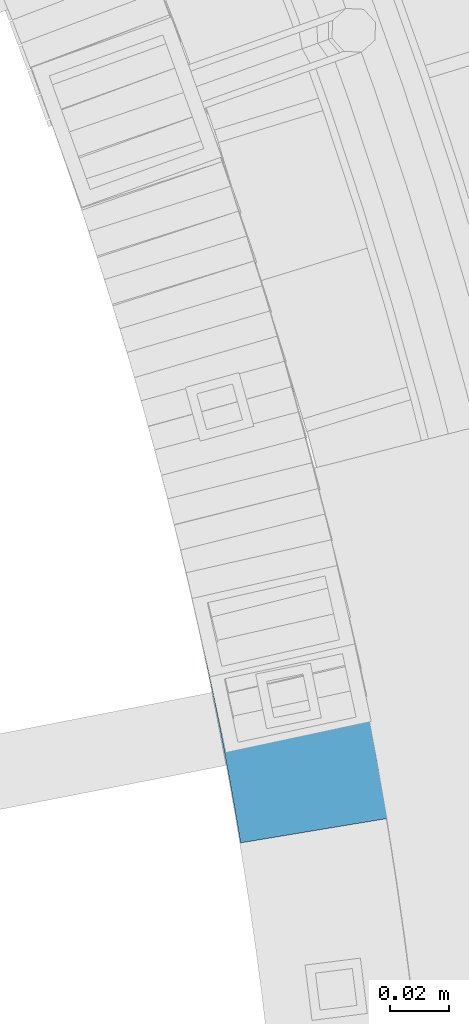
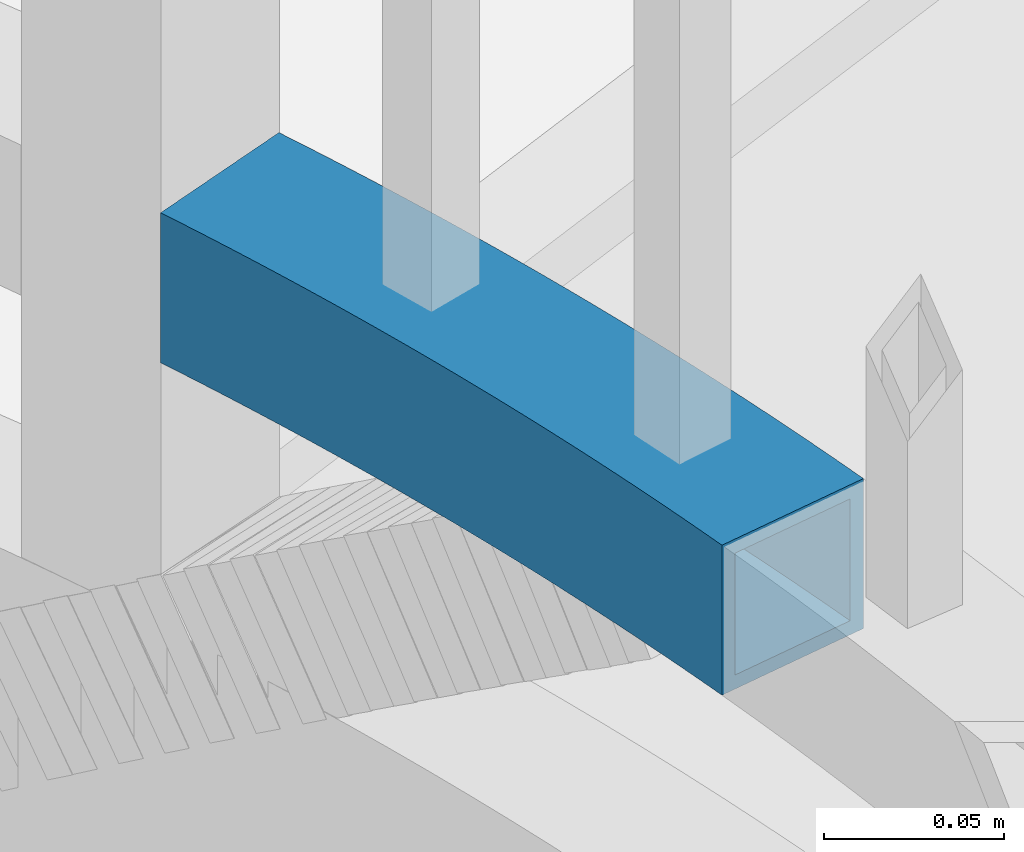
# One storey, part 501 of 975: 1 beam.
"""IFC2X3 building model written with IfcOpenShell, lengths in millimetres."""

from ifc_helpers import new_model, si_unit, frame, origin_with_axes, place, context, subcontext, project, spatial, faceted_brep, material, type_object, element, save


model = new_model("IFC2X3")

# Units and contexts
model_context = context("Model", 3, precision=1e-05, world=origin_with_axes())
body_context = subcontext(model_context, "Body", "Model", "MODEL_VIEW")
ifc_project = project(units=[si_unit("LENGTHUNIT", "METRE", prefix="MILLI"), si_unit("AREAUNIT", "SQUARE_METRE"), si_unit("VOLUMEUNIT", "CUBIC_METRE"), si_unit("MASSUNIT", "GRAM", prefix="KILO"), si_unit("TIMEUNIT", "SECOND"), si_unit("PLANEANGLEUNIT", "RADIAN"), si_unit("SOLIDANGLEUNIT", "STERADIAN"), si_unit("THERMODYNAMICTEMPERATUREUNIT", "DEGREE_CELSIUS"), si_unit("LUMINOUSINTENSITYUNIT", "LUMEN")], contexts=[model_context])

# Site, building, storey
site_placement = place(None, origin_with_axes())
site = spatial("IfcSite", under=ifc_project, at=site_placement, CompositionType="ELEMENT")
building_placement = place(site_placement, origin_with_axes())
building = spatial("IfcBuilding", under=site, at=building_placement, Name="Undefined", CompositionType="ELEMENT")
storey_placement = place(building_placement, origin_with_axes())
storey = spatial("IfcBuildingStorey", under=building, at=storey_placement, Name="Undefined", CompositionType="ELEMENT", Elevation=0.0)

# Beam
ifc_material = material()
beam_type = type_object("IfcBeamType", Name="HSS2X2X.188_TUBES", PredefinedType="NOTDEFINED")
beam_placement = place(storey_placement, frame((36048.7809654732, 3877.2993769869, 2298.70000076294), z_axis=(0.0, 0.0, 1.0), x_axis=(0.252202304925183, -0.967674530712897, 0.0)))
element("IfcBeam", 1, at=beam_placement, inside=storey, type_object=beam_type, material=ifc_material, Name="HANDRAIL", ObjectType="HSS2X2X.188_TUBES", context=body_context, shape_type="Brep", body=[
    faceted_brep([(23.9244235525521, 27.4337792830265, -25.4000000000001), (23.9244235525521, 27.4337792830265, 25.4000000000001), (28.2983125438623, 27.7431184082016, 25.4000000000001), (28.2983125438623, 27.7431184082016, -25.4000000000001), (32.673130547797, 28.0390289269781, 25.4000000000001), (32.673130547797, 28.0390289269781, -25.4000000000001), (37.0488363362747, 28.3215080507071, 25.4000000000001), (37.0488363362747, 28.3215080507071, -25.4000000000001), (41.4253886728502, 28.5905531173339, 25.4000000000001), (41.4253886728502, 28.5905531173339, -25.4000000000001), (45.8027463131011, 28.846161591362, 25.4000000000001), (45.8027463131011, 28.846161591362, -25.4000000000001), (50.1808680050126, 29.0883310639838, 25.4000000000001), (50.1808680050126, 29.0883310639838, -25.4000000000001), (54.5597124893729, 29.3170592529859, 25.4000000000001), (54.5597124893729, 29.3170592529859, -25.4000000000001), (58.9392385001574, 29.5323440028515, 25.4000000000001), (58.9392385001574, 29.5323440028515, -25.4000000000001), (63.3194047649195, 29.7341832847378, 25.4000000000001), (63.3194047649195, 29.7341832847378, -25.4000000000001), (67.7001700051733, 29.9225751965278, 25.4000000000001), (67.7001700051733, 29.9225751965278, -25.4000000000001), (72.0814929367998, 30.0975179628367, 25.4000000000001), (72.0814929367998, 30.0975179628367, -25.4000000000001), (76.4633322704121, 30.2590099349909, 25.4000000000001), (76.4633322704121, 30.2590099349909, -25.4000000000001), (80.845646711763, 30.4070495911074, 25.4000000000001), (80.845646711763, 30.4070495911074, -25.4000000000001), (85.2283949621278, 30.5416355360649, 25.4000000000001), (85.2283949621278, 30.5416355360649, -25.4000000000001), (89.6115357186954, 30.662766501533, 25.4000000000001), (89.6115357186954, 30.662766501533, -25.4000000000001), (93.995027674945, 30.7704413459796, 25.4000000000001), (93.995027674945, 30.7704413459796, -25.4000000000001), (98.3788295210634, 30.864659054685, 25.4000000000001), (98.3788295210634, 30.864659054685, -25.4000000000001), (102.762899944306, 30.9454187397423, 25.4000000000001), (102.762899944306, 30.9454187397423, -25.4000000000001), (107.147197629394, 31.012719640079, 25.4000000000001), (107.147197629394, 31.012719640079, -25.4000000000001), (111.531681258915, 31.0665611214499, 25.4000000000001), (111.531681258915, 31.0665611214499, -25.4000000000001), (115.916309513703, 31.1069426764516, 25.4000000000001), (115.916309513703, 31.1069426764516, -25.4000000000001), (120.301041073226, 31.1338639245441, 25.4000000000001), (120.301041073226, 31.1338639245441, -25.4000000000001), (124.685834615975, 31.1473246120149, 25.4000000000001), (124.685834615975, 31.1473246120149, -25.4000000000001), (129.070648819868, 31.1473246120077, 25.4000000000001), (129.070648819868, 31.1473246120077, -25.4000000000001), (133.45544236262, 31.1338639245296, 25.4000000000001), (133.45544236262, 31.1338639245296, -25.4000000000001), (137.840173922141, 31.106942676437, 25.4000000000001), (137.840173922141, 31.106942676437, -25.4000000000001), (142.224802176928, 31.0665611214208, 25.4000000000001), (142.224802176928, 31.0665611214208, -25.4000000000001), (146.609285806451, 31.0127196400354, 25.4000000000001), (146.609285806451, 31.0127196400354, -25.4000000000001), (150.99358349154, 30.9454187396914, 25.4000000000001), (150.99358349154, 30.9454187396914, -25.4000000000001), (155.377653914779, 30.8646590546268, 25.4000000000001), (155.377653914779, 30.8646590546268, -25.4000000000001), (159.761455760896, 30.7704413459142, 25.4000000000001), (159.761455760896, 30.7704413459142, -25.4000000000001), (164.14494771715, 30.662766501453, 25.4000000000001), (164.14494771715, 30.662766501453, -25.4000000000001), (168.528088473715, 30.5416355359775, 25.4000000000001), (168.528088473715, 30.5416355359775, -25.4000000000001), (172.910836724081, 30.4070495910128, 25.4000000000001), (172.910836724081, 30.4070495910128, -25.4000000000001), (177.293151165432, 30.259009934889, 25.4000000000001), (177.293151165432, 30.259009934889, -25.4000000000001), (181.674990499043, 30.0975179627276, 25.4000000000001), (181.674990499043, 30.0975179627276, -25.4000000000001), (186.056313430669, 29.9225751964186, 25.4000000000001), (186.056313430669, 29.9225751964186, -25.4000000000001), (190.437078670922, 29.7341832846068, 25.4000000000001), (190.437078670922, 29.7341832846068, -25.4000000000001), (194.817244935684, 29.5323440027132, 25.4000000000001), (194.817244935684, 29.5323440027132, -25.4000000000001), (199.19677094647, 29.3170592528477, 25.4000000000001), (199.19677094647, 29.3170592528477, -25.4000000000001), (203.575615430829, 29.088331063831, 25.4000000000001), (203.575615430829, 29.088331063831, -25.4000000000001), (207.953737122741, 28.846161591202, 25.4000000000001), (207.953737122741, 28.846161591202, -25.4000000000001), (212.33109476299, 28.590553117152, 25.4000000000001), (212.33109476299, 28.590553117152, -25.4000000000001), (216.707647099567, 28.3215080505252, 25.4000000000001), (216.707647099567, 28.3215080505252, -25.4000000000001), (221.083352888043, 28.0390289267889, 25.4000000000001), (221.083352888043, 28.0390289267889, -25.4000000000001), (225.458170891976, 27.7431184080051, 25.4000000000001), (225.458170891976, 27.7431184080051, -25.4000000000001), (229.832059883287, 27.4337792828301, 25.4000000000001), (229.832059883287, 27.4337792828301, -25.4000000000001), (234.204978642647, 27.111014466449, 25.4000000000001), (234.204978642647, 27.111014466449, -25.4000000000001), (238.576885959879, 26.774827000605, 25.4000000000001), (238.576885959879, 26.774827000605, -25.4000000000001), (242.947740634334, 26.4252200534829, 25.4000000000001), (242.947740634334, 26.4252200534829, -25.4000000000001), (247.317501475278, 26.0621969197819, 25.4000000000001), (247.317501475278, 26.0621969197819, -25.4000000000001), (251.686127302295, 25.6857610206207, 25.4000000000001), (251.686127302295, 25.6857610206207, -25.4000000000001), (247.247270868133, -24.9199358283295, 25.4000000000001), (247.247270868133, -24.9199358283295, -25.4000000000001), (251.45938992594, -25.2959159039965, -25.4000000000001), (251.45938992594, -25.2959159039965, 25.4000000000001), (243.034017458249, -24.5568880649007, 25.4000000000001), (243.034017458249, -24.5568880649007, -25.4000000000001), (238.819669401789, -24.2067760350546, 25.4000000000001), (238.819669401789, -24.2067760350546, -25.4000000000001), (234.604266414571, -23.8696030382416, 25.4000000000001), (234.604266414571, -23.8696030382416, -25.4000000000001), (230.387848222354, -23.5453722519596, 25.4000000000001), (230.387848222354, -23.5453722519596, -25.4000000000001), (226.170454560464, -23.2340867317544, 25.4000000000001), (226.170454560464, -23.2340867317544, -25.4000000000001), (221.952125173425, -22.9357494111391, 25.4000000000001), (221.952125173425, -22.9357494111391, -25.4000000000001), (217.732899814573, -22.6503631016603, 25.4000000000001), (217.732899814573, -22.6503631016603, -25.4000000000001), (213.512818245687, -22.3779304927666, 25.4000000000001), (213.512818245687, -22.3779304927666, -25.4000000000001), (209.291920236621, -22.1184541518596, 25.4000000000001), (209.291920236621, -22.1184541518596, -25.4000000000001), (205.070245564919, -21.8719365242287, 25.4000000000001), (205.070245564919, -21.8719365242287, -25.4000000000001), (200.847834015442, -21.6383799330506, 25.4000000000001), (200.847834015442, -21.6383799330506, -25.4000000000001), (196.624725380004, -21.417786579339, 25.4000000000001), (196.624725380004, -21.417786579339, -25.4000000000001), (192.400959456976, -21.2101585419587, 25.4000000000001), (192.400959456976, -21.2101585419587, -25.4000000000001), (188.176576050933, -21.0154977775965, 25.4000000000001), (188.176576050933, -21.0154977775965, -25.4000000000001), (183.951614972266, -20.8338061207178, 25.4000000000001), (183.951614972266, -20.8338061207178, -25.4000000000001), (179.726116036809, -20.665085283581, 25.4000000000001), (179.726116036809, -20.665085283581, -25.4000000000001), (175.500119065468, -20.5093368562011, 25.4000000000001), (175.500119065468, -20.5093368562011, -25.4000000000001), (171.273663883836, -20.366562306328, 25.4000000000001), (171.273663883836, -20.366562306328, -25.4000000000001), (167.04679032183, -20.2367629794899, 25.4000000000001), (167.04679032183, -20.2367629794899, -25.4000000000001), (162.819538213309, -20.119940098899, 25.4000000000001), (162.819538213309, -20.119940098899, -25.4000000000001), (158.591947395696, -20.0160947654877, 25.4000000000001), (158.591947395696, -20.0160947654877, -25.4000000000001), (154.36405770961, -19.9252279578795, 25.4000000000001), (154.36405770961, -19.9252279578795, -25.4000000000001), (150.135908998488, -19.8473405324185, 25.4000000000001), (150.135908998488, -19.8473405324185, -25.4000000000001), (145.907541108198, -19.782433223103, 25.4000000000001), (145.907541108198, -19.782433223103, -25.4000000000001), (141.678993886684, -19.7305066416084, 25.4000000000001), (141.678993886684, -19.7305066416084, -25.4000000000001), (137.450307183581, -19.6915612772937, 25.4000000000001), (137.450307183581, -19.6915612772937, -25.4000000000001), (133.221520849826, -19.66559749718, 25.4000000000001), (133.221520849826, -19.66559749718, -25.4000000000001), (128.992674737305, -19.6526155459651, 25.4000000000001), (128.992674737305, -19.6526155459651, -25.4000000000001), (124.763808698468, -19.6526155459578, 25.4000000000001), (124.763808698468, -19.6526155459578, -25.4000000000001), (120.53496258595, -19.6655974971727, 25.4000000000001), (120.53496258595, -19.6655974971727, -25.4000000000001), (116.306176252194, -19.6915612772718, 25.4000000000001), (116.306176252194, -19.6915612772718, -25.4000000000001), (112.077489549089, -19.7305066415793, 25.4000000000001), (112.077489549089, -19.7305066415793, -25.4000000000001), (107.848942327575, -19.7824332230521, 25.4000000000001), (107.848942327575, -19.7824332230521, -25.4000000000001), (103.620574437287, -19.8473405323675, 25.4000000000001), (103.620574437287, -19.8473405323675, -25.4000000000001), (99.3924257261606, -19.9252279578286, 25.4000000000001), (99.3924257261606, -19.9252279578286, -25.4000000000001), (95.1645360400762, -20.0160947654294, 25.4000000000001), (95.1645360400762, -20.0160947654294, -25.4000000000001), (90.9369452224619, -20.1199400988262, 25.4000000000001), (90.9369452224619, -20.1199400988262, -25.4000000000001), (86.7096931139422, -20.2367629794026, 25.4000000000001), (86.7096931139422, -20.2367629794026, -25.4000000000001), (82.4828195519367, -20.3665623062479, 25.4000000000001), (82.4828195519367, -20.3665623062479, -25.4000000000001), (78.2563643703052, -20.5093368560993, 25.4000000000001), (78.2563643703052, -20.5093368560993, -25.4000000000001), (74.030367398962, -20.6650852834719, 25.4000000000001), (74.030367398962, -20.6650852834719, -25.4000000000001), (69.804868463506, -20.8338061206014, 25.4000000000001), (69.804868463506, -20.8338061206014, -25.4000000000001), (65.5799073848393, -21.0154977774728, 25.4000000000001), (65.5799073848393, -21.0154977774728, -25.4000000000001), (61.3555239787947, -21.2101585418277, 25.4000000000001), (61.3555239787947, -21.2101585418277, -25.4000000000001), (57.1317580557679, -21.4177865791935, 25.4000000000001), (57.1317580557679, -21.4177865791935, -25.4000000000001), (52.9086494203275, -21.6383799329051, 25.4000000000001), (52.9086494203275, -21.6383799329051, -25.4000000000001), (48.686237870852, -21.8719365240759, 25.4000000000001), (48.686237870852, -21.8719365240759, -25.4000000000001), (44.4645631991498, -22.1184541516996, 25.4000000000001), (44.4645631991498, -22.1184541516996, -25.4000000000001), (40.2436651900807, -22.3779304925993, 25.4000000000001), (40.2436651900807, -22.3779304925993, -25.4000000000001), (36.0235836211959, -22.6503631014784, 25.4000000000001), (36.0235836211959, -22.6503631014784, -25.4000000000001), (31.8043582623432, -22.9357494109499, 25.4000000000001), (31.8043582623432, -22.9357494109499, -25.4000000000001), (27.5860288753038, -23.2340867315434, 25.4000000000001), (27.5860288753038, -23.2340867315434, -25.4000000000001), (256.053576945661, 25.2959159035017, -25.4000000000001), (23.01928277346, 27.3669709078022, -25.4000000000001), (23.01928277346, 27.3669709078022, 25.4000000000001), (256.053576945661, 25.2959159035017, 25.4000000000001), (24.2676990515611, 22.6836668441683, 20.6374999999998), (24.2676990515611, 22.6836668441683, -20.6374999999998), (28.6270043299701, 22.9919745501538, -20.6374999999998), (28.6270043299701, 22.9919745501538, 20.6374999999998), (32.9872355234274, 23.2868984243105, -20.6374999999998), (32.9872355234274, 23.2868984243105, 20.6374999999998), (37.3483515413191, 23.5684356872734, -20.6374999999998), (37.3483515413191, 23.5684356872734, 20.6374999999998), (41.7103112846899, 23.8365836858575, -20.6374999999998), (41.7103112846899, 23.8365836858575, 20.6374999999998), (46.0730736466403, 24.0913398930425, -20.6374999999998), (46.0730736466403, 24.0913398930425, 20.6374999999998), (50.4365975126984, 24.3327019080243, -20.6374999999998), (50.4365975126984, 24.3327019080243, 20.6374999999998), (54.8008417612236, 24.5606674562223, -20.6374999999998), (54.8008417612236, 24.5606674562223, 20.6374999999998), (59.1657652637805, 24.7752343892862, -20.6374999999998), (59.1657652637805, 24.7752343892862, 20.6374999999998), (63.5313268855361, 24.9764006851619, -20.6374999999998), (63.5313268855361, 24.9764006851619, 20.6374999999998), (67.8974854856442, 25.1641644480551, -20.6374999999998), (67.8974854856442, 25.1641644480551, 20.6374999999998), (72.2641999176276, 25.3385239084964, -20.6374999999998), (72.2641999176276, 25.3385239084964, 20.6374999999998), (76.6314290297751, 25.4994774233201, -20.6374999999998), (76.6314290297751, 25.4994774233201, 20.6374999999998), (80.9991316655296, 25.6470234757289, -20.6374999999998), (80.9991316655296, 25.6470234757289, 20.6374999999998), (85.3672666638613, 25.7811606752366, -20.6374999999998), (85.3672666638613, 25.7811606752366, 20.6374999999998), (89.7357928596721, 25.9018877577546, -20.6374999999998), (89.7357928596721, 25.9018877577546, 20.6374999999998), (94.1046690841777, 26.0092035855414, -20.6374999999998), (94.1046690841777, 26.0092035855414, 20.6374999999998), (98.4738541652914, 26.1031071472607, -20.6374999999998), (98.4738541652914, 26.1031071472607, 20.6374999999998), (102.843306928022, 26.1835975579743, -20.6374999999998), (102.843306928022, 26.1835975579743, 20.6374999999998), (107.212986194849, 26.2506740591634, -20.6374999999998), (107.212986194849, 26.2506740591634, 20.6374999999998), (111.582850786119, 26.3043360186639, -20.6374999999998), (111.582850786119, 26.3043360186639, 20.6374999999998), (115.952859520437, 26.3445829307966, -20.6374999999998), (115.952859520437, 26.3445829307966, 20.6374999999998), (120.322971215042, 26.3714144162659, -20.6374999999998), (120.322971215042, 26.3714144162659, 20.6374999999998), (124.693144686208, 26.3848302222104, -20.6374999999998), (124.693144686208, 26.3848302222104, 20.6374999999998), (129.063338749627, 26.3848302222032, -20.6374999999998), (129.063338749627, 26.3848302222032, 20.6374999999998), (133.433512220796, 26.3714144162441, -20.6374999999998), (133.433512220796, 26.3714144162441, 20.6374999999998), (137.803623915402, 26.3445829307821, -20.6374999999998), (137.803623915402, 26.3445829307821, 20.6374999999998), (142.173632649718, 26.3043360186348, -20.6374999999998), (142.173632649718, 26.3043360186348, 20.6374999999998), (146.543497240989, 26.2506740591198, -20.6374999999998), (146.543497240989, 26.2506740591198, 20.6374999999998), (150.913176507815, 26.1835975579306, -20.6374999999998), (150.913176507815, 26.1835975579306, 20.6374999999998), (155.282629270547, 26.1031071472098, -20.6374999999998), (155.282629270547, 26.1031071472098, 20.6374999999998), (159.651814351661, 26.0092035854759, -20.6374999999998), (159.651814351661, 26.0092035854759, 20.6374999999998), (164.020690576165, 25.9018877576746, -20.6374999999998), (164.020690576165, 25.9018877576746, 20.6374999999998), (168.389216771978, 25.7811606751566, -20.6374999999998), (168.389216771978, 25.7811606751566, 20.6374999999998), (172.757351770308, 25.6470234756416, -20.6374999999998), (172.757351770308, 25.6470234756416, 20.6374999999998), (177.12505440606, 25.4994774232255, -20.6374999999998), (177.12505440606, 25.4994774232255, 20.6374999999998), (181.49228351821, 25.3385239083873, -20.6374999999998), (181.49228351821, 25.3385239083873, 20.6374999999998), (185.858997950194, 25.1641644479387, -20.6374999999998), (185.858997950194, 25.1641644479387, 20.6374999999998), (190.225156550299, 24.976400685031, -20.6374999999998), (190.225156550299, 24.976400685031, 20.6374999999998), (194.590718172055, 24.775234389148, -20.6374999999998), (194.590718172055, 24.775234389148, 20.6374999999998), (198.955641674613, 24.5606674560768, -20.6374999999998), (198.955641674613, 24.5606674560768, 20.6374999999998), (203.319885923135, 24.3327019078715, -20.6374999999998), (203.319885923135, 24.3327019078715, 20.6374999999998), (207.683409789193, 24.0913398928824, -20.6374999999998), (207.683409789193, 24.0913398928824, 20.6374999999998), (212.046172151142, 23.8365836856829, -20.6374999999998), (212.046172151142, 23.8365836856829, 20.6374999999998), (216.408131894515, 23.5684356870916, -20.6374999999998), (216.408131894515, 23.5684356870916, 20.6374999999998), (220.769247912405, 23.286898424114, -20.6374999999998), (220.769247912405, 23.286898424114, 20.6374999999998), (225.129479105864, 22.9919745499574, -20.6374999999998), (225.129479105864, 22.9919745499574, 20.6374999999998), (229.488784384273, 22.6836668439573, -20.6374999999998), (229.488784384273, 22.6836668439573, 20.6374999999998), (233.847122665745, 22.3619782116002, -20.6374999999998), (233.847122665745, 22.3619782116002, 20.6374999999998), (238.204452877508, 22.0269116844574, -20.6374999999998), (238.204452877508, 22.0269116844574, 20.6374999999998), (242.560733956283, 21.6784704201855, -20.6374999999998), (242.560733956283, 21.6784704201855, 20.6374999999998), (246.915924848683, 21.3166577024749, -20.6374999999998), (246.915924848683, 21.3166577024749, 20.6374999999998), (251.269984511593, 20.9414769410359, -20.6374999999998), (251.269984511593, 20.9414769410359, 20.6374999999998), (255.622871912561, 20.5529316715474, -20.6374999999998), (255.622871912561, 20.5529316715474, 20.6374999999998), (251.890094959037, -20.5529316720495, 20.6374999999998), (251.890094959037, -20.5529316720495, -20.6374999999998), (247.663413658835, -20.1756517487374, -20.6374999999998), (247.663413658835, -20.1756517487374, 20.6374999999998), (243.435594084845, -19.8113488475865, -20.6374999999998), (243.435594084845, -19.8113488475865, 20.6374999999998), (239.206676079839, -19.4600264017572, -20.6374999999998), (239.206676079839, -19.4600264017572, 20.6374999999998), (234.976699496943, -19.1216877221013, -20.6374999999998), (234.976699496943, -19.1216877221013, 20.6374999999998), (230.745704199257, -18.7963359971181, -20.6374999999998), (230.745704199257, -18.7963359971181, 20.6374999999998), (226.513730059479, -18.4839742928816, -20.6374999999998), (226.513730059479, -18.4839742928816, 20.6374999999998), (222.280816959539, -18.1846055530987, -20.6374999999998), (222.280816959539, -18.1846055530987, 20.6374999999998), (218.047004790211, -17.8982325989928, -20.6374999999998), (218.047004790211, -17.8982325989928, 20.6374999999998), (213.812333450738, -17.624858129333, -20.6374999999998), (213.812333450738, -17.624858129333, 20.6374999999998), (209.57684284847, -17.3644847203905, -20.6374999999998), (209.57684284847, -17.3644847203905, 20.6374999999998), (205.340572898464, -17.1171148259091, -20.6374999999998), (205.340572898464, -17.1171148259091, 20.6374999999998), (201.103563523135, -16.8827507770839, -20.6374999999998), (201.103563523135, -16.8827507770839, 20.6374999999998), (196.865854651859, -16.6613947825681, -20.6374999999998), (196.865854651859, -16.6613947825681, 20.6374999999998), (192.627486220605, -16.4530489283934, -20.6374999999998), (192.627486220605, -16.4530489283934, 20.6374999999998), (188.388498171558, -16.2577151780133, -20.6374999999998), (188.388498171558, -16.2577151780133, 20.6374999999998), (184.148930452742, -16.0753953722378, -20.6374999999998), (184.148930452742, -16.0753953722378, 20.6374999999998), (179.908823017646, -15.9060912292334, -20.6374999999998), (179.908823017646, -15.9060912292334, 20.6374999999998), (175.66821582484, -15.7498043445303, -20.6374999999998), (175.66821582484, -15.7498043445303, 20.6374999999998), (171.427148837609, -15.6065361909568, -20.6374999999998), (171.427148837609, -15.6065361909568, 20.6374999999998), (167.185662023569, -15.4762881186689, -20.6374999999998), (167.185662023569, -15.4762881186689, 20.6374999999998), (162.943795354294, -15.3590613551205, -20.6374999999998), (162.943795354294, -15.3590613551205, 20.6374999999998), (158.701588804934, -15.2548570050421, -20.6374999999998), (158.701588804934, -15.2548570050421, 20.6374999999998), (154.459082353847, -15.1636760504553, -20.6374999999998), (154.459082353847, -15.1636760504553, 20.6374999999998), (150.21631598221, -15.0855193506577, -20.6374999999998), (150.21631598221, -15.0855193506577, 20.6374999999998), (145.973329673659, -15.0203876421801, -20.6374999999998), (145.973329673659, -15.0203876421801, 20.6374999999998), (141.730163413895, -14.9682815388223, -20.6374999999998), (141.730163413895, -14.9682815388223, 20.6374999999998), (137.486857190319, -14.9292015316314, -20.6374999999998), (137.486857190319, -14.9292015316314, 20.6374999999998), (133.243450991649, -14.9031479888945, -20.6374999999998), (133.243450991649, -14.9031479888945, 20.6374999999998), (128.999984807546, -14.8901211561461, -20.6374999999998), (128.999984807546, -14.8901211561461, 20.6374999999998), (124.756498628234, -14.8901211561461, -20.6374999999998), (124.756498628234, -14.8901211561461, 20.6374999999998), (120.513032444131, -14.9031479888799, -20.6374999999998), (120.513032444131, -14.9031479888799, 20.6374999999998), (116.269626245461, -14.9292015316169, -20.6374999999998), (116.269626245461, -14.9292015316169, 20.6374999999998), (112.026320021885, -14.968281538786, -20.6374999999998), (112.026320021885, -14.968281538786, 20.6374999999998), (107.78315376212, -15.0203876421365, -20.6374999999998), (107.78315376212, -15.0203876421365, 20.6374999999998), (103.540167453568, -15.085519350614, -20.6374999999998), (103.540167453568, -15.085519350614, 20.6374999999998), (99.2974010819325, -15.1636760504043, -20.6374999999998), (99.2974010819325, -15.1636760504043, 20.6374999999998), (95.0548946308445, -15.2548570049767, -20.6374999999998), (95.0548946308445, -15.2548570049767, 20.6374999999998), (90.8126880814852, -15.3590613550405, -20.6374999999998), (90.8126880814852, -15.3590613550405, 20.6374999999998), (86.5708214122096, -15.4762881185889, -20.6374999999998), (86.5708214122096, -15.4762881185889, 20.6374999999998), (82.3293345981701, -15.6065361908622, -20.6374999999998), (82.3293345981701, -15.6065361908622, 20.6374999999998), (78.0882676109386, -15.7498043444357, -20.6374999999998), (78.0882676109386, -15.7498043444357, 20.6374999999998), (73.8476604181342, -15.9060912291316, -20.6374999999998), (73.8476604181342, -15.9060912291316, 20.6374999999998), (69.6075529830368, -16.0753953721287, -20.6374999999998), (69.6075529830368, -16.0753953721287, 20.6374999999998), (65.3679852642199, -16.2577151778969, -20.6374999999998), (65.3679852642199, -16.2577151778969, 20.6374999999998), (61.1289972151726, -16.4530489282697, -20.6374999999998), (61.1289972151726, -16.4530489282697, 20.6374999999998), (56.89062878392, -16.6613947824299, -20.6374999999998), (56.89062878392, -16.6613947824299, 20.6374999999998), (52.6529199126417, -16.8827507769456, -20.6374999999998), (52.6529199126417, -16.8827507769456, 20.6374999999998), (48.4159105373128, -17.117114825749, -20.6374999999998), (48.4159105373128, -17.117114825749, 20.6374999999998), (44.1796405873083, -17.3644847202304, -20.6374999999998), (44.1796405873083, -17.3644847202304, 20.6374999999998), (39.9441499850363, -17.6248581291657, -20.6374999999998), (39.9441499850363, -17.6248581291657, 20.6374999999998), (35.7094786455655, -17.8982325988109, -20.6374999999998), (35.7094786455655, -17.8982325988109, 20.6374999999998), (31.4756664762353, -18.1846055529022, -20.6374999999998), (31.4756664762353, -18.1846055529022, 20.6374999999998), (27.2427533762948, -18.4839742926852, 20.6374999999998), (23.4519885908921, 22.6234593142435, 20.6374999999998), (23.4519885908921, 22.6234593142435, -20.6374999999998), (27.2427533762948, -18.4839742926852, -20.6374999999998)], [[[0, 1, 2, 3]], [[3, 2, 4, 5]], [[5, 4, 6, 7]], [[7, 6, 8, 9]], [[9, 8, 10, 11]], [[11, 10, 12, 13]], [[13, 12, 14, 15]], [[15, 14, 16, 17]], [[17, 16, 18, 19]], [[19, 18, 20, 21]], [[21, 20, 22, 23]], [[23, 22, 24, 25]], [[25, 24, 26, 27]], [[27, 26, 28, 29]], [[29, 28, 30, 31]], [[31, 30, 32, 33]], [[33, 32, 34, 35]], [[35, 34, 36, 37]], [[37, 36, 38, 39]], [[39, 38, 40, 41]], [[41, 40, 42, 43]], [[43, 42, 44, 45]], [[45, 44, 46, 47]], [[47, 46, 48, 49]], [[49, 48, 50, 51]], [[51, 50, 52, 53]], [[53, 52, 54, 55]], [[55, 54, 56, 57]], [[57, 56, 58, 59]], [[59, 58, 60, 61]], [[61, 60, 62, 63]], [[63, 62, 64, 65]], [[65, 64, 66, 67]], [[67, 66, 68, 69]], [[69, 68, 70, 71]], [[71, 70, 72, 73]], [[73, 72, 74, 75]], [[75, 74, 76, 77]], [[77, 76, 78, 79]], [[79, 78, 80, 81]], [[81, 80, 82, 83]], [[83, 82, 84, 85]], [[85, 84, 86, 87]], [[87, 86, 88, 89]], [[89, 88, 90, 91]], [[91, 90, 92, 93]], [[93, 92, 94, 95]], [[95, 94, 96, 97]], [[97, 96, 98, 99]], [[99, 98, 100, 101]], [[101, 100, 102, 103]], [[103, 102, 104, 105]], [[106, 107, 108, 109]], [[110, 111, 107, 106]], [[112, 113, 111, 110]], [[114, 115, 113, 112]], [[116, 117, 115, 114]], [[118, 119, 117, 116]], [[120, 121, 119, 118]], [[122, 123, 121, 120]], [[124, 125, 123, 122]], [[126, 127, 125, 124]], [[128, 129, 127, 126]], [[130, 131, 129, 128]], [[132, 133, 131, 130]], [[134, 135, 133, 132]], [[136, 137, 135, 134]], [[138, 139, 137, 136]], [[140, 141, 139, 138]], [[142, 143, 141, 140]], [[144, 145, 143, 142]], [[146, 147, 145, 144]], [[148, 149, 147, 146]], [[150, 151, 149, 148]], [[152, 153, 151, 150]], [[154, 155, 153, 152]], [[156, 157, 155, 154]], [[158, 159, 157, 156]], [[160, 161, 159, 158]], [[162, 163, 161, 160]], [[164, 165, 163, 162]], [[166, 167, 165, 164]], [[168, 169, 167, 166]], [[170, 171, 169, 168]], [[172, 173, 171, 170]], [[174, 175, 173, 172]], [[176, 177, 175, 174]], [[178, 179, 177, 176]], [[180, 181, 179, 178]], [[182, 183, 181, 180]], [[184, 185, 183, 182]], [[186, 187, 185, 184]], [[188, 189, 187, 186]], [[190, 191, 189, 188]], [[192, 193, 191, 190]], [[194, 195, 193, 192]], [[196, 197, 195, 194]], [[198, 199, 197, 196]], [[200, 201, 199, 198]], [[202, 203, 201, 200]], [[204, 205, 203, 202]], [[206, 207, 205, 204]], [[208, 209, 207, 206]], [[210, 211, 209, 208]], [[211, 210, 212, 213]], [[0, 3, 5, 7, 9, 11, 13, 15, 17, 19, 21, 23, 25, 27, 29, 31, 33, 35, 37, 39, 41, 43, 45, 47, 49, 51, 53, 55, 57, 59, 61, 63, 65, 67, 69, 71, 73, 75, 77, 79, 81, 83, 85, 87, 89, 91, 93, 95, 97, 99, 101, 103, 105, 214, 108, 107, 111, 113, 115, 117, 119, 121, 123, 125, 127, 129, 131, 133, 135, 137, 139, 141, 143, 145, 147, 149, 151, 153, 155, 157, 159, 161, 163, 165, 167, 169, 171, 173, 175, 177, 179, 181, 183, 185, 187, 189, 191, 193, 195, 197, 199, 201, 203, 205, 207, 209, 211, 213, 215]], [[1, 0, 215, 216]], [[210, 208, 206, 204, 202, 200, 198, 196, 194, 192, 190, 188, 186, 184, 182, 180, 178, 176, 174, 172, 170, 168, 166, 164, 162, 160, 158, 156, 154, 152, 150, 148, 146, 144, 142, 140, 138, 136, 134, 132, 130, 128, 126, 124, 122, 120, 118, 116, 114, 112, 110, 106, 109, 217, 104, 102, 100, 98, 96, 94, 92, 90, 88, 86, 84, 82, 80, 78, 76, 74, 72, 70, 68, 66, 64, 62, 60, 58, 56, 54, 52, 50, 48, 46, 44, 42, 40, 38, 36, 34, 32, 30, 28, 26, 24, 22, 20, 18, 16, 14, 12, 10, 8, 6, 4, 2, 1, 216, 212]], [[105, 104, 217, 214]], [[218, 219, 220, 221]], [[221, 220, 222, 223]], [[223, 222, 224, 225]], [[225, 224, 226, 227]], [[227, 226, 228, 229]], [[229, 228, 230, 231]], [[231, 230, 232, 233]], [[233, 232, 234, 235]], [[235, 234, 236, 237]], [[237, 236, 238, 239]], [[239, 238, 240, 241]], [[241, 240, 242, 243]], [[243, 242, 244, 245]], [[245, 244, 246, 247]], [[247, 246, 248, 249]], [[249, 248, 250, 251]], [[251, 250, 252, 253]], [[253, 252, 254, 255]], [[255, 254, 256, 257]], [[257, 256, 258, 259]], [[259, 258, 260, 261]], [[261, 260, 262, 263]], [[263, 262, 264, 265]], [[265, 264, 266, 267]], [[267, 266, 268, 269]], [[269, 268, 270, 271]], [[271, 270, 272, 273]], [[273, 272, 274, 275]], [[275, 274, 276, 277]], [[277, 276, 278, 279]], [[279, 278, 280, 281]], [[281, 280, 282, 283]], [[283, 282, 284, 285]], [[285, 284, 286, 287]], [[287, 286, 288, 289]], [[289, 288, 290, 291]], [[291, 290, 292, 293]], [[293, 292, 294, 295]], [[295, 294, 296, 297]], [[297, 296, 298, 299]], [[299, 298, 300, 301]], [[301, 300, 302, 303]], [[303, 302, 304, 305]], [[305, 304, 306, 307]], [[307, 306, 308, 309]], [[309, 308, 310, 311]], [[311, 310, 312, 313]], [[313, 312, 314, 315]], [[315, 314, 316, 317]], [[317, 316, 318, 319]], [[319, 318, 320, 321]], [[321, 320, 322, 323]], [[323, 322, 324, 325]], [[109, 108, 214, 217], [326, 325, 324, 327]], [[328, 329, 326, 327]], [[330, 331, 329, 328]], [[332, 333, 331, 330]], [[334, 335, 333, 332]], [[336, 337, 335, 334]], [[338, 339, 337, 336]], [[340, 341, 339, 338]], [[342, 343, 341, 340]], [[344, 345, 343, 342]], [[346, 347, 345, 344]], [[348, 349, 347, 346]], [[350, 351, 349, 348]], [[352, 353, 351, 350]], [[354, 355, 353, 352]], [[356, 357, 355, 354]], [[358, 359, 357, 356]], [[360, 361, 359, 358]], [[362, 363, 361, 360]], [[364, 365, 363, 362]], [[366, 367, 365, 364]], [[368, 369, 367, 366]], [[370, 371, 369, 368]], [[372, 373, 371, 370]], [[374, 375, 373, 372]], [[376, 377, 375, 374]], [[378, 379, 377, 376]], [[380, 381, 379, 378]], [[382, 383, 381, 380]], [[384, 385, 383, 382]], [[386, 387, 385, 384]], [[388, 389, 387, 386]], [[390, 391, 389, 388]], [[392, 393, 391, 390]], [[394, 395, 393, 392]], [[396, 397, 395, 394]], [[398, 399, 397, 396]], [[400, 401, 399, 398]], [[402, 403, 401, 400]], [[404, 405, 403, 402]], [[406, 407, 405, 404]], [[408, 409, 407, 406]], [[410, 411, 409, 408]], [[412, 413, 411, 410]], [[414, 415, 413, 412]], [[416, 417, 415, 414]], [[418, 419, 417, 416]], [[420, 421, 419, 418]], [[422, 423, 421, 420]], [[424, 425, 423, 422]], [[426, 427, 425, 424]], [[428, 429, 427, 426]], [[430, 431, 429, 428]], [[218, 221, 223, 225, 227, 229, 231, 233, 235, 237, 239, 241, 243, 245, 247, 249, 251, 253, 255, 257, 259, 261, 263, 265, 267, 269, 271, 273, 275, 277, 279, 281, 283, 285, 287, 289, 291, 293, 295, 297, 299, 301, 303, 305, 307, 309, 311, 313, 315, 317, 319, 321, 323, 325, 326, 329, 331, 333, 335, 337, 339, 341, 343, 345, 347, 349, 351, 353, 355, 357, 359, 361, 363, 365, 367, 369, 371, 373, 375, 377, 379, 381, 383, 385, 387, 389, 391, 393, 395, 397, 399, 401, 403, 405, 407, 409, 411, 413, 415, 417, 419, 421, 423, 425, 427, 429, 431, 432, 433]], [[219, 218, 433, 434]], [[430, 428, 426, 424, 422, 420, 418, 416, 414, 412, 410, 408, 406, 404, 402, 400, 398, 396, 394, 392, 390, 388, 386, 384, 382, 380, 378, 376, 374, 372, 370, 368, 366, 364, 362, 360, 358, 356, 354, 352, 350, 348, 346, 344, 342, 340, 338, 336, 334, 332, 330, 328, 327, 324, 322, 320, 318, 316, 314, 312, 310, 308, 306, 304, 302, 300, 298, 296, 294, 292, 290, 288, 286, 284, 282, 280, 278, 276, 274, 272, 270, 268, 266, 264, 262, 260, 258, 256, 254, 252, 250, 248, 246, 244, 242, 240, 238, 236, 234, 232, 230, 228, 226, 224, 222, 220, 219, 434, 435]], [[431, 430, 435, 432]], [[215, 213, 212, 216], [434, 433, 432, 435]]]),
])

save(model, "model.ifc")
